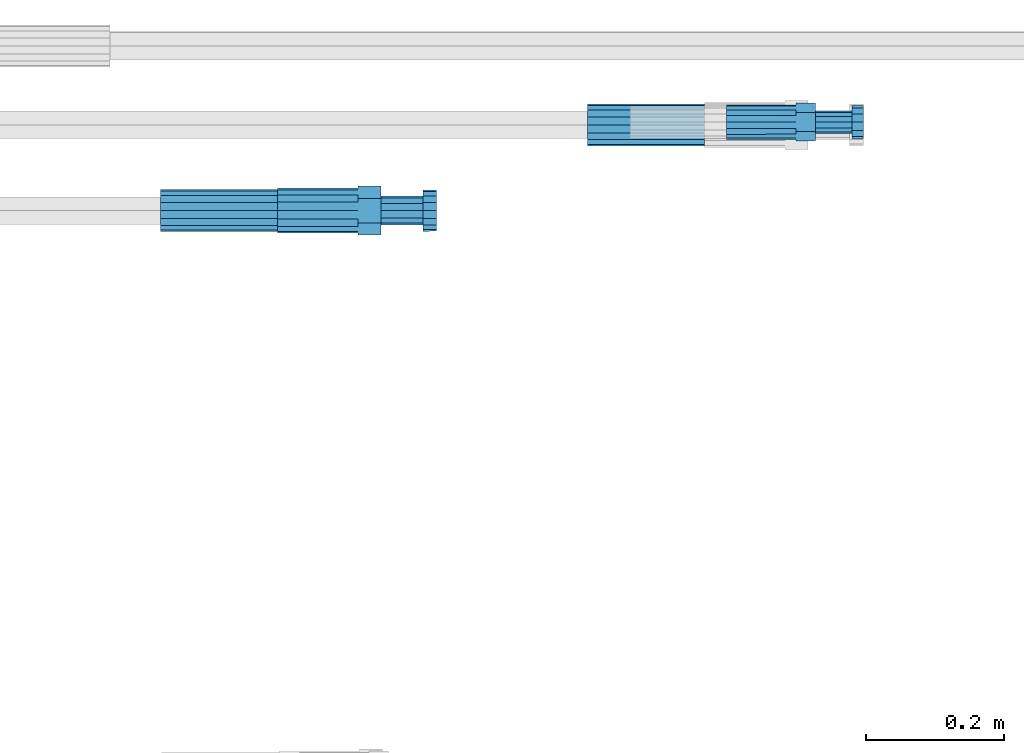
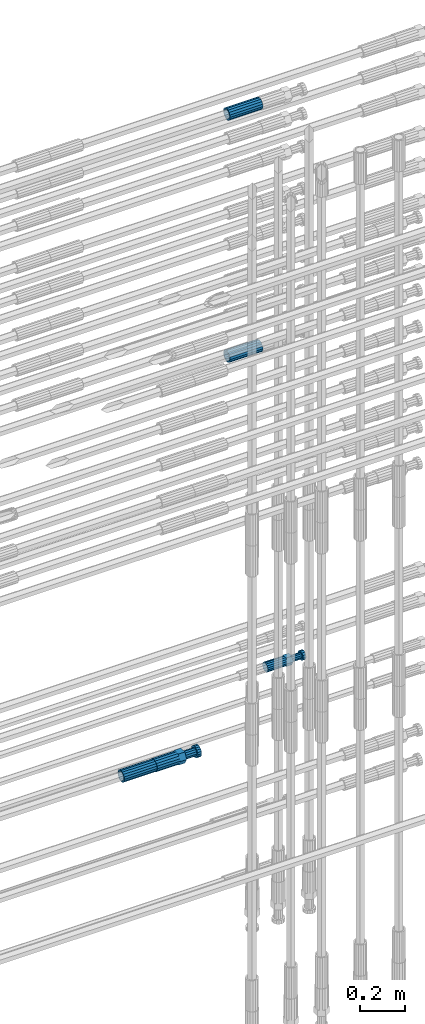
# One storey, part 109 of 119: 5 beams.
"""IFC2X3 building model written with IfcOpenShell, lengths in millimetres."""

from ifc_helpers import new_model, si_unit, frame, origin_with_axes, place, context, subcontext, project, spatial, faceted_brep, material, type_object, element, save


model = new_model("IFC2X3")

# Units and contexts
model_context = context("Model", 3, precision=1e-05, world=origin_with_axes())
body_context = subcontext(model_context, "Body", "Model", "MODEL_VIEW")
ifc_project = project(units=[si_unit("LENGTHUNIT", "METRE", prefix="MILLI"), si_unit("AREAUNIT", "SQUARE_METRE"), si_unit("VOLUMEUNIT", "CUBIC_METRE"), si_unit("MASSUNIT", "GRAM", prefix="KILO"), si_unit("TIMEUNIT", "SECOND"), si_unit("PLANEANGLEUNIT", "RADIAN"), si_unit("SOLIDANGLEUNIT", "STERADIAN"), si_unit("THERMODYNAMICTEMPERATUREUNIT", "DEGREE_CELSIUS"), si_unit("LUMINOUSINTENSITYUNIT", "LUMEN")], contexts=[model_context])

# Site, building, storey
site_placement = place(None, origin_with_axes())
site = spatial("IfcSite", under=ifc_project, at=site_placement, CompositionType="ELEMENT")
building_placement = place(site_placement, origin_with_axes())
building = spatial("IfcBuilding", under=site, at=building_placement, Name="Undefined", CompositionType="ELEMENT")
storey_placement = place(building_placement, origin_with_axes())
storey = spatial("IfcBuildingStorey", under=building, at=storey_placement, Name="Undefined", CompositionType="ELEMENT", Elevation=0.0)

# Beams
ifc_material = material(Name="STEEL/S275")
beam_type_1 = type_object("IfcBeamType", PredefinedType="NOTDEFINED")
beam_1_placement = place(storey_placement, frame((2038589.02023304, 6206285.48994599, 21026.9894117228), z_axis=(0.0, 0.0, 1.0), x_axis=(1.0, 0.0, 0.0)))
element("IfcBeam", 1, at=beam_1_placement, inside=storey, type_object=beam_type_1, material=ifc_material, Name="AG40N", context=body_context, shape_type="Brep", body=[
    faceted_brep([(1.62981450557709e-09, -23.4999999990687, 0.0), (7.45058059692383e-09, -21.7111690142192, 8.99306066057534), (170.000002125278, -21.711168999318, 8.99306066022245), (170.000002127141, -23.4999999844003, -3.66071617463604e-10), (4.65661287307739e-09, -16.6170093587134, 16.6170093578889), (170.000002122484, -16.6170093440451, 16.6170093575288), (1.86264514923096e-09, -8.99306066217832, 21.7111690140277), (170.000002118759, -8.99306064750999, 21.7111690136603), (2.3283064365387e-10, 9.31322574615479e-10, 23.5), (170.000002114102, 1.28056854009628e-08, 23.4999999996485), (-6.51925802230835e-09, 8.99306065868586, 21.7111690140241), (170.00000211224, 8.99306067335419, 21.7111690136639), (-7.45058059692383e-09, 16.6170093561523, 16.6170093578853), (170.000002109446, 16.6170093708206, 16.6170093575324), (-9.31322574615479e-09, 21.711169013055, 8.99306066057534), (170.000002108514, 21.7111690277234, 8.99306066022245), (-1.16415321826935e-09, 23.5000000009313, 0.0), (170.000002108514, 23.5000000144355, -3.66071617463604e-10), (-8.38190317153931e-09, 21.7111690151505, -8.99306066059444), (170.000002110377, 21.7111690300517, -8.9930606609546), (-5.58793544769287e-09, 16.6170093598776, -16.6170093579008), (170.000002113171, 16.6170093745459, -16.6170093582609), (-9.31322574615479e-10, 8.99306066334248, -21.7111690140396), (170.000002115965, 8.99306067801081, -21.7111690143961), (2.3283064365387e-10, 9.31322574615479e-10, -23.5), (170.00000211969, 1.7927959561348e-08, -23.5000000003843), (5.58793544769287e-09, -8.99306065752171, -21.7111690140396), (170.000002123415, -8.99306064285338, -21.7111690143961), (8.38190317153931e-09, -16.6170093549881, -16.6170093579008), (170.000002125278, -16.6170093403198, -16.6170093582646), (9.31322574615479e-09, -21.7111690121237, -8.99306066059444), (170.000002127141, -21.7111689972226, -8.9930606609546), (1.11758708953857e-08, -30.4999999990687, -9.54969436861575e-12), (1.30385160446167e-08, -28.1783257392235, -11.6718446871514), (170.000002129003, -28.1783257243223, -11.6718446875116), (170.000002129935, -30.4999999841675, -3.66071617463604e-10), (1.02445483207703e-08, -21.5667568228673, -21.5667568262129), (170.000002128072, -21.566756808199, -21.5667568265694), (7.45058059692383e-09, -11.6718446831219, -28.1783257416196), (170.000002125278, -11.6718446684536, -28.1783257419834), (3.72529029846191e-09, 3.95812094211578e-09, -30.5000000000277), (170.00000211969, 1.83936208486557e-08, -30.5000000003879), (-9.31322574615479e-10, 11.6718446905725, -28.1783257416232), (170.000002115965, 11.6718447052408, -28.1783257419797), (-6.51925802230835e-09, 21.5667568286881, -21.5667568262093), (170.000002110377, 21.5667568433564, -21.5667568265694), (-9.31322574615479e-09, 28.178325742716, -11.6718446871478), (170.000002108514, 28.1783257573843, -11.6718446875079), (-1.21071934700012e-08, 30.5, -5.91171556152403e-12), (170.000002106652, 30.5000000144355, -3.62433638656512e-10), (-1.21071934700012e-08, 28.1783257401548, 11.6718446871359), (170.00000210572, 28.1783257548232, 11.6718446867794), (-1.02445483207703e-08, 21.5667568240315, 21.5667568261974), (170.000002107583, 21.566756838467, 21.5667568258409), (-7.45058059692383e-09, 11.671844684286, 28.1783257416041), (170.000002110377, 11.6718446989544, 28.178325741244), (-2.79396772384644e-09, -2.56113708019257e-09, 30.5000000000159), (170.000002114102, 1.18743628263474e-08, 30.4999999996558), (1.86264514923096e-09, -11.6718446896411, 28.1783257416114), (170.000002118759, -11.67184467474, 28.178325741244), (7.45058059692383e-09, -21.5667568275239, 21.5667568261974), (170.000002123415, -21.5667568126228, 21.5667568258373), (1.02445483207703e-08, -28.1783257415518, 11.6718446871359), (170.000002127141, -28.1783257271163, 11.6718446867794)], [[[0, 1, 2, 3]], [[1, 4, 5, 2]], [[4, 6, 7, 5]], [[6, 8, 9, 7]], [[8, 10, 11, 9]], [[10, 12, 13, 11]], [[12, 14, 15, 13]], [[14, 16, 17, 15]], [[16, 18, 19, 17]], [[18, 20, 21, 19]], [[20, 22, 23, 21]], [[22, 24, 25, 23]], [[24, 26, 27, 25]], [[26, 28, 29, 27]], [[28, 30, 31, 29]], [[30, 0, 3, 31]], [[32, 33, 34, 35]], [[33, 36, 37, 34]], [[36, 38, 39, 37]], [[38, 40, 41, 39]], [[40, 42, 43, 41]], [[42, 44, 45, 43]], [[44, 46, 47, 45]], [[46, 48, 49, 47]], [[48, 50, 51, 49]], [[50, 52, 53, 51]], [[52, 54, 55, 53]], [[54, 56, 57, 55]], [[56, 58, 59, 57]], [[58, 60, 61, 59]], [[60, 62, 63, 61]], [[62, 32, 35, 63]], [[37, 39, 41, 43, 45, 47, 49, 51, 53, 55, 57, 59, 61, 63, 35, 34], [5, 7, 9, 11, 13, 15, 17, 19, 21, 23, 25, 27, 29, 31, 3, 2]], [[62, 60, 58, 56, 54, 52, 50, 48, 46, 44, 42, 40, 38, 36, 33, 32], [30, 28, 26, 24, 22, 20, 18, 16, 14, 12, 10, 8, 6, 4, 1, 0]]]),
])
beam_2_placement = place(storey_placement, frame((2038589.02023304, 6206285.48994599, 22354.9894117228), z_axis=(0.0, 0.0, 1.0), x_axis=(1.0, 0.0, 0.0)))
element("IfcBeam", 2, at=beam_2_placement, inside=storey, type_object=beam_type_1, material=ifc_material, Name="AG40N", context=body_context, shape_type="Brep", body=[
    faceted_brep([(1.62981450557709e-09, -23.4999999990687, 0.0), (7.45058059692383e-09, -21.7111690142192, 8.99306066057534), (170.000002125278, -21.711168999318, 8.99306066022245), (170.000002127141, -23.4999999844003, -3.66071617463604e-10), (4.65661287307739e-09, -16.6170093587134, 16.6170093578889), (170.000002122484, -16.6170093440451, 16.6170093575288), (1.86264514923096e-09, -8.99306066217832, 21.7111690140277), (170.000002118759, -8.99306064750999, 21.7111690136603), (2.3283064365387e-10, 9.31322574615479e-10, 23.5), (170.000002114102, 1.28056854009628e-08, 23.4999999996485), (-6.51925802230835e-09, 8.99306065868586, 21.7111690140241), (170.00000211224, 8.99306067335419, 21.7111690136639), (-7.45058059692383e-09, 16.6170093561523, 16.6170093578853), (170.000002109446, 16.6170093708206, 16.6170093575324), (-9.31322574615479e-09, 21.711169013055, 8.99306066057534), (170.000002108514, 21.7111690277234, 8.99306066022245), (-1.16415321826935e-09, 23.5000000009313, 0.0), (170.000002108514, 23.5000000144355, -3.66071617463604e-10), (-8.38190317153931e-09, 21.7111690151505, -8.99306066059444), (170.000002110377, 21.7111690300517, -8.9930606609546), (-5.58793544769287e-09, 16.6170093598776, -16.6170093579008), (170.000002113171, 16.6170093745459, -16.6170093582609), (-9.31322574615479e-10, 8.99306066334248, -21.7111690140396), (170.000002115965, 8.99306067801081, -21.7111690143961), (2.3283064365387e-10, 9.31322574615479e-10, -23.5), (170.00000211969, 1.7927959561348e-08, -23.5000000003843), (5.58793544769287e-09, -8.99306065752171, -21.7111690140396), (170.000002123415, -8.99306064285338, -21.7111690143961), (8.38190317153931e-09, -16.6170093549881, -16.6170093579008), (170.000002125278, -16.6170093403198, -16.6170093582646), (9.31322574615479e-09, -21.7111690121237, -8.99306066059444), (170.000002127141, -21.7111689972226, -8.9930606609546), (1.11758708953857e-08, -30.4999999990687, -9.54969436861575e-12), (1.30385160446167e-08, -28.1783257392235, -11.6718446871514), (170.000002129003, -28.1783257243223, -11.6718446875116), (170.000002129935, -30.4999999841675, -3.66071617463604e-10), (1.02445483207703e-08, -21.5667568228673, -21.5667568262129), (170.000002128072, -21.566756808199, -21.5667568265694), (7.45058059692383e-09, -11.6718446831219, -28.1783257416196), (170.000002125278, -11.6718446684536, -28.1783257419834), (3.72529029846191e-09, 3.95812094211578e-09, -30.5000000000277), (170.00000211969, 1.83936208486557e-08, -30.5000000003879), (-9.31322574615479e-10, 11.6718446905725, -28.1783257416232), (170.000002115965, 11.6718447052408, -28.1783257419797), (-6.51925802230835e-09, 21.5667568286881, -21.5667568262093), (170.000002110377, 21.5667568433564, -21.5667568265694), (-9.31322574615479e-09, 28.178325742716, -11.6718446871478), (170.000002108514, 28.1783257573843, -11.6718446875079), (-1.21071934700012e-08, 30.5, -5.91171556152403e-12), (170.000002106652, 30.5000000144355, -3.62433638656512e-10), (-1.21071934700012e-08, 28.1783257401548, 11.6718446871359), (170.00000210572, 28.1783257548232, 11.6718446867794), (-1.02445483207703e-08, 21.5667568240315, 21.5667568261974), (170.000002107583, 21.566756838467, 21.5667568258409), (-7.45058059692383e-09, 11.671844684286, 28.1783257416041), (170.000002110377, 11.6718446989544, 28.178325741244), (-2.79396772384644e-09, -2.56113708019257e-09, 30.5000000000159), (170.000002114102, 1.18743628263474e-08, 30.4999999996558), (1.86264514923096e-09, -11.6718446896411, 28.1783257416114), (170.000002118759, -11.67184467474, 28.178325741244), (7.45058059692383e-09, -21.5667568275239, 21.5667568261974), (170.000002123415, -21.5667568126228, 21.5667568258373), (1.02445483207703e-08, -28.1783257415518, 11.6718446871359), (170.000002127141, -28.1783257271163, 11.6718446867794)], [[[0, 1, 2, 3]], [[1, 4, 5, 2]], [[4, 6, 7, 5]], [[6, 8, 9, 7]], [[8, 10, 11, 9]], [[10, 12, 13, 11]], [[12, 14, 15, 13]], [[14, 16, 17, 15]], [[16, 18, 19, 17]], [[18, 20, 21, 19]], [[20, 22, 23, 21]], [[22, 24, 25, 23]], [[24, 26, 27, 25]], [[26, 28, 29, 27]], [[28, 30, 31, 29]], [[30, 0, 3, 31]], [[32, 33, 34, 35]], [[33, 36, 37, 34]], [[36, 38, 39, 37]], [[38, 40, 41, 39]], [[40, 42, 43, 41]], [[42, 44, 45, 43]], [[44, 46, 47, 45]], [[46, 48, 49, 47]], [[48, 50, 51, 49]], [[50, 52, 53, 51]], [[52, 54, 55, 53]], [[54, 56, 57, 55]], [[56, 58, 59, 57]], [[58, 60, 61, 59]], [[60, 62, 63, 61]], [[62, 32, 35, 63]], [[37, 39, 41, 43, 45, 47, 49, 51, 53, 55, 57, 59, 61, 63, 35, 34], [5, 7, 9, 11, 13, 15, 17, 19, 21, 23, 25, 27, 29, 31, 3, 2]], [[62, 60, 58, 56, 54, 52, 50, 48, 46, 44, 42, 40, 38, 36, 33, 32], [30, 28, 26, 24, 22, 20, 18, 16, 14, 12, 10, 8, 6, 4, 1, 0]]]),
])
beam_3_placement = place(storey_placement, frame((2037969.03023304, 6206160.98994599, 19018.4894151562), z_axis=(0.0, 0.0, 1.0), x_axis=(1.0, 0.0, 0.0)))
element("IfcBeam", 3, at=beam_3_placement, inside=storey, type_object=beam_type_1, material=ifc_material, Name="AG40N", context=body_context, shape_type="Brep", body=[
    faceted_brep([(1.62981450557709e-09, -23.4999999990687, 0.0), (7.45058059692383e-09, -21.7111690142192, 8.99306066057534), (170.000002125278, -21.711168999318, 8.99306066022245), (170.000002127141, -23.4999999844003, -3.66071617463604e-10), (4.65661287307739e-09, -16.6170093587134, 16.6170093578889), (170.000002122484, -16.6170093440451, 16.6170093575288), (1.86264514923096e-09, -8.99306066217832, 21.7111690140277), (170.000002118759, -8.99306064750999, 21.7111690136603), (2.3283064365387e-10, 9.31322574615479e-10, 23.5), (170.000002114102, 1.28056854009628e-08, 23.4999999996485), (-6.51925802230835e-09, 8.99306065868586, 21.7111690140241), (170.00000211224, 8.99306067335419, 21.7111690136639), (-7.45058059692383e-09, 16.6170093561523, 16.6170093578853), (170.000002109446, 16.6170093708206, 16.6170093575324), (-9.31322574615479e-09, 21.711169013055, 8.99306066057534), (170.000002108514, 21.7111690277234, 8.99306066022245), (-1.16415321826935e-09, 23.5000000009313, 0.0), (170.000002108514, 23.5000000144355, -3.66071617463604e-10), (-8.38190317153931e-09, 21.7111690151505, -8.99306066059444), (170.000002110377, 21.7111690300517, -8.9930606609546), (-5.58793544769287e-09, 16.6170093598776, -16.6170093579008), (170.000002113171, 16.6170093745459, -16.6170093582609), (-9.31322574615479e-10, 8.99306066334248, -21.7111690140396), (170.000002115965, 8.99306067801081, -21.7111690143961), (2.3283064365387e-10, 9.31322574615479e-10, -23.5), (170.00000211969, 1.7927959561348e-08, -23.5000000003843), (5.58793544769287e-09, -8.99306065752171, -21.7111690140396), (170.000002123415, -8.99306064285338, -21.7111690143961), (8.38190317153931e-09, -16.6170093549881, -16.6170093579008), (170.000002125278, -16.6170093403198, -16.6170093582646), (9.31322574615479e-09, -21.7111690121237, -8.99306066059444), (170.000002127141, -21.7111689972226, -8.9930606609546), (1.11758708953857e-08, -30.4999999990687, -9.54969436861575e-12), (1.30385160446167e-08, -28.1783257392235, -11.6718446871514), (170.000002129003, -28.1783257243223, -11.6718446875116), (170.000002129935, -30.4999999841675, -3.66071617463604e-10), (1.02445483207703e-08, -21.5667568228673, -21.5667568262129), (170.000002128072, -21.566756808199, -21.5667568265694), (7.45058059692383e-09, -11.6718446831219, -28.1783257416196), (170.000002125278, -11.6718446684536, -28.1783257419834), (3.72529029846191e-09, 3.95812094211578e-09, -30.5000000000277), (170.00000211969, 1.83936208486557e-08, -30.5000000003879), (-9.31322574615479e-10, 11.6718446905725, -28.1783257416232), (170.000002115965, 11.6718447052408, -28.1783257419797), (-6.51925802230835e-09, 21.5667568286881, -21.5667568262093), (170.000002110377, 21.5667568433564, -21.5667568265694), (-9.31322574615479e-09, 28.178325742716, -11.6718446871478), (170.000002108514, 28.1783257573843, -11.6718446875079), (-1.21071934700012e-08, 30.5, -5.91171556152403e-12), (170.000002106652, 30.5000000144355, -3.62433638656512e-10), (-1.21071934700012e-08, 28.1783257401548, 11.6718446871359), (170.00000210572, 28.1783257548232, 11.6718446867794), (-1.02445483207703e-08, 21.5667568240315, 21.5667568261974), (170.000002107583, 21.566756838467, 21.5667568258409), (-7.45058059692383e-09, 11.671844684286, 28.1783257416041), (170.000002110377, 11.6718446989544, 28.178325741244), (-2.79396772384644e-09, -2.56113708019257e-09, 30.5000000000159), (170.000002114102, 1.18743628263474e-08, 30.4999999996558), (1.86264514923096e-09, -11.6718446896411, 28.1783257416114), (170.000002118759, -11.67184467474, 28.178325741244), (7.45058059692383e-09, -21.5667568275239, 21.5667568261974), (170.000002123415, -21.5667568126228, 21.5667568258373), (1.02445483207703e-08, -28.1783257415518, 11.6718446871359), (170.000002127141, -28.1783257271163, 11.6718446867794)], [[[0, 1, 2, 3]], [[1, 4, 5, 2]], [[4, 6, 7, 5]], [[6, 8, 9, 7]], [[8, 10, 11, 9]], [[10, 12, 13, 11]], [[12, 14, 15, 13]], [[14, 16, 17, 15]], [[16, 18, 19, 17]], [[18, 20, 21, 19]], [[20, 22, 23, 21]], [[22, 24, 25, 23]], [[24, 26, 27, 25]], [[26, 28, 29, 27]], [[28, 30, 31, 29]], [[30, 0, 3, 31]], [[32, 33, 34, 35]], [[33, 36, 37, 34]], [[36, 38, 39, 37]], [[38, 40, 41, 39]], [[40, 42, 43, 41]], [[42, 44, 45, 43]], [[44, 46, 47, 45]], [[46, 48, 49, 47]], [[48, 50, 51, 49]], [[50, 52, 53, 51]], [[52, 54, 55, 53]], [[54, 56, 57, 55]], [[56, 58, 59, 57]], [[58, 60, 61, 59]], [[60, 62, 63, 61]], [[62, 32, 35, 63]], [[37, 39, 41, 43, 45, 47, 49, 51, 53, 55, 57, 59, 61, 63, 35, 34], [5, 7, 9, 11, 13, 15, 17, 19, 21, 23, 25, 27, 29, 31, 3, 2]], [[62, 60, 58, 56, 54, 52, 50, 48, 46, 44, 42, 40, 38, 36, 33, 32], [30, 28, 26, 24, 22, 20, 18, 16, 14, 12, 10, 8, 6, 4, 1, 0]]]),
])
beam_type_2 = type_object("IfcBeamType", Name="ROD65", PredefinedType="NOTDEFINED")
beam_4_placement = place(storey_placement, frame((2038139.03023304, 6206160.98994599, 19018.4894184159), z_axis=(0.0, 0.0, 1.0), x_axis=(1.0, 0.0, 0.0)))
element("IfcBeam", 4, at=beam_4_placement, inside=storey, type_object=beam_type_2, material=ifc_material, Name="AGB40", ObjectType="ROD65", context=body_context, shape_type="Brep", body=[
    faceted_brep([(116.999999999069, 17.8249999252148, 30.8738056446964), (116.999999998137, 22.0056957420893, 23.632628078838), (116.999999999069, 12.4372115600854, 30.0260848066173), (116.999999999069, 8.17543111252598, 30.8738056446964), (117.000000000931, -17.8250000746921, 30.8738056446964), (150.200000001118, -17.8250000723638, 30.8738056446964), (150.199999999255, 17.8249999275431, 30.8738056446964), (117.000000000931, -8.17543109622784, 30.8738056446964), (117.000000001863, -22.0056959956419, 23.6326278985034), (117.000000000931, -12.4372115437873, 30.0260848066173), (117.000000001863, -35.6500000746455, -2.18278728425503e-10), (150.200000002049, -35.6500000723172, -2.18278728425503e-10), (117.000000001863, -30.8443149488885, 8.32369080289209), (117.000000001863, -30.8443149488885, -8.32369080355784), (117.000000002794, -32.4999999918509, 0.0), (117.000000000931, -17.8250000746921, -30.873805645133), (150.200000001118, -17.8250000723638, -30.873805645133), (117.000000001863, -22.0056959961075, -23.6326278982269), (117.000000000931, -8.17543109389953, -30.873805645133), (117.000000000931, -12.4372115437873, -30.0260848066173), (116.999999999069, 17.8249999252148, -30.873805645133), (150.199999999255, 17.8249999275431, -30.873805645133), (116.999999999069, 8.17543111019768, -30.873805645133), (116.999999999069, 12.4372115600854, -30.0260848066173), (116.999999998137, 22.005695742555, -23.6326280785652), (116.999999998137, 35.6499999251682, -2.18278728425503e-10), (150.199999998324, 35.6499999277294, -2.18278728425503e-10), (116.999999998137, 30.8443150522653, -8.32369036550881), (116.999999997206, 32.5000000081491, 0.0), (116.999999998137, 30.8443150522653, 8.32369036483942), (1.86264514923096e-09, -22.9809703885112, 22.9809703885621), (1.86264514923096e-09, -30.0260848065373, 12.4372115518672), (117.000000001863, -30.0260847983882, 12.4372115518672), (117.000000001863, -22.9809703803621, 22.9809703885621), (-1.86264514923096e-09, 22.9809703885112, -22.9809703885621), (-1.86264514923096e-09, 30.0260848065373, -12.4372115518672), (116.999999998137, 30.0260848146863, -12.4372115518672), (116.999999998137, 22.9809703966603, -22.9809703885621), (1.86264514923096e-09, -30.0260848065373, -12.4372115518672), (1.86264514923096e-09, -22.9809703885112, -22.9809703885621), (117.000000001863, -22.9809703803621, -22.9809703885621), (117.000000001863, -30.0260847983882, -12.4372115518672), (9.31322574615479e-10, -12.4372115519363, 30.0260848066173), (0.0, 0.0, 32.5), (-9.31322574615479e-10, 12.4372115519363, 30.0260848066173), (-1.86264514923096e-09, 22.9809703885112, 22.9809703885621), (-1.86264514923096e-09, 30.0260848065373, 12.4372115518672), (-2.79396772384644e-09, 32.5, 0.0), (-9.31322574615479e-10, 12.4372115519363, -30.0260848066173), (0.0, 0.0, -32.5), (9.31322574615479e-10, -12.4372115519363, -30.0260848066173), (2.79396772384644e-09, -32.5, 0.0), (116.999999998137, 22.9809703966603, 22.9809703885621), (116.999999998137, 30.0260848146863, 12.4372115518672), (117.0, 8.14907252788544e-09, -32.5), (117.0, 8.14907252788544e-09, 32.5), (150.200000000186, -10.5000000959262, 18.1865334791873), (150.199999999255, -9.59262251853943e-08, 20.9999999997126), (150.199999998324, 10.4999999040738, 18.1865334791873), (150.199999997392, 18.1865333835594, 10.4999999997126), (150.199999997392, 20.9999999040738, -2.87400325760245e-10), (150.199999997392, 18.1865333835594, -10.5000000002874), (150.199999998324, 10.4999999040738, -18.1865334797621), (150.199999999255, -9.59262251853943e-08, -21.0000000002874), (150.200000000186, -10.5000000959262, -18.1865334797621), (150.200000000186, -18.1865335754119, -10.5000000002874), (150.200000001118, -21.0000000959262, -2.87400325760245e-10), (150.200000000186, -18.1865335754119, 10.4999999997126), (210.979999999516, 10.4999999082647, 18.1865334791873), (210.979999999516, -9.17352735996246e-08, 20.9999999997126), (210.979999997653, 18.1865333877504, 10.4999999997126), (210.979999997653, 20.9999999082647, -2.87400325760245e-10), (210.979999997653, 18.1865333877504, -10.5000000002874), (210.979999999516, 10.4999999082647, -18.1865334797621), (210.979999999516, -9.17352735996246e-08, -21.0000000002874), (210.979999999516, -10.5000000917353, -18.1865334797621), (210.980000000447, -18.1865335712209, -10.5000000002874), (210.980000001378, -21.0000000917353, -2.87400325760245e-10), (210.980000000447, -18.1865335712209, 10.4999999997126), (210.979999999516, -10.5000000917353, 18.1865334791873), (211.001368402503, -27.7269939335529, -11.4911163272045), (211.003082515672, -21.2238095656503, -21.2238154190527), (231.002518340945, -21.2131946226582, -21.2132004554769), (231.000804228708, -27.7163789905608, -11.4805013636287), (211.001368415542, -11.4911086384673, -27.7269970399575), (231.000804241747, -11.4804936954752, -27.7163820763781), (210.996487061493, -0.0106066407170147, -30.0106107396168), (230.995922887698, 8.30227509140968e-06, -29.999995776041), (210.98918159306, 11.4698940692469, -27.7269970332745), (230.988617419265, 11.4805090120062, -27.7163820696951), (210.980564201251, 21.2025913291145, -21.2238154067054), (230.980000027455, 21.2132062721066, -21.2132004431296), (210.971946807578, 27.7057702087332, -11.4911163110701), (230.971382633783, 27.7163851517253, -11.4805013474943), (210.964641331695, 29.9893806746695, -0.0106149565435771), (230.9640771579, 29.9999956176616, 7.03221303410828e-09), (210.959759964608, 27.7057637346443, 11.4698863966551), (230.959195790812, 27.7163786776364, 11.4805013602345), (210.958045851439, 21.2025793667417, 21.2025854885032), (230.957481677644, 21.2131943097338, 21.2132004520827), (210.959759951569, 11.4698784395587, 27.705767109408), (230.959195776843, 11.4804933823179, 27.7163820729838), (210.964641305618, -0.0106235581915826, 29.9893808090674), (230.964077131823, -8.61519947648048e-06, 29.9999957726432), (210.971946774051, -11.4911242681555, 27.7057671027251), (230.971382599324, -11.4805093251634, 27.7163820663009), (210.98056416586, -21.2238215280231, 21.2025854761559), (230.979999991134, -21.2132065852638, 21.2132004397354), (210.989181559533, -27.7270004076418, 11.4698863805206), (230.988617384806, -27.7163854646496, 11.4805013441), (210.996487035416, -30.0106108735781, -0.0106149740058754), (230.995922861621, -29.999995930586, -1.04300852399319e-08)], [[[0, 1, 2, 3]], [[4, 5, 6, 0, 3, 7]], [[8, 4, 7, 9]], [[10, 11, 5, 4, 8, 12]], [[13, 10, 12, 14]], [[15, 16, 11, 10, 13, 17]], [[18, 15, 17, 19]], [[20, 21, 16, 15, 18, 22]], [[20, 22, 23, 24]], [[25, 26, 21, 20, 24, 27]], [[25, 27, 28, 29]], [[30, 31, 32, 33]], [[34, 35, 36, 37]], [[38, 39, 40, 41]], [[31, 30, 42, 43, 44, 45, 46, 47, 35, 34, 48, 49, 50, 39, 38, 51]], [[46, 45, 52, 53]], [[28, 47, 46, 53, 29]], [[27, 36, 35, 47, 28]], [[24, 37, 36, 27]], [[23, 48, 34, 37, 24]], [[22, 54, 49, 48, 23]], [[18, 54, 22]], [[19, 50, 49, 54, 18]], [[17, 40, 39, 50, 19]], [[13, 41, 40, 17]], [[14, 51, 38, 41, 13]], [[12, 32, 31, 51, 14]], [[8, 33, 32, 12]], [[9, 42, 30, 33, 8]], [[7, 55, 43, 42, 9]], [[3, 55, 7]], [[2, 44, 43, 55, 3]], [[1, 52, 45, 44, 2]], [[29, 53, 52, 1]], [[0, 6, 26, 25, 29, 1]], [[5, 11, 16, 21, 26, 6], [56, 57, 58, 59, 60, 61, 62, 63, 64, 65, 66, 67]], [[68, 58, 57, 69]], [[70, 59, 58, 68]], [[71, 60, 59, 70]], [[72, 61, 60, 71]], [[73, 62, 61, 72]], [[74, 63, 62, 73]], [[75, 64, 63, 74]], [[76, 65, 64, 75]], [[77, 66, 65, 76]], [[78, 67, 66, 77]], [[79, 56, 67, 78]], [[69, 57, 56, 79]], [[80, 81, 82, 83]], [[81, 84, 85, 82]], [[84, 86, 87, 85]], [[86, 88, 89, 87]], [[88, 90, 91, 89]], [[90, 92, 93, 91]], [[92, 94, 95, 93]], [[94, 96, 97, 95]], [[96, 98, 99, 97]], [[98, 100, 101, 99]], [[100, 102, 103, 101]], [[102, 104, 105, 103]], [[104, 106, 107, 105]], [[106, 108, 109, 107]], [[108, 110, 111, 109]], [[82, 85, 87, 89, 91, 93, 95, 97, 99, 101, 103, 105, 107, 109, 111, 83]], [[110, 80, 83, 111]], [[108, 106, 104, 102, 100, 98, 96, 94, 92, 90, 88, 86, 84, 81, 80, 110], [78, 77, 76, 75, 74, 73, 72, 71, 70, 68, 69, 79]]]),
])
beam_type_3 = type_object("IfcBeamType", Name="ROD50", PredefinedType="NOTDEFINED")
beam_5_placement = place(storey_placement, frame((2038791.00023304, 6206289.47994599, 19249.489419125), z_axis=(0.0, 0.0, 1.0), x_axis=(1.0, 0.0, 0.0)))
element("IfcBeam", 5, at=beam_5_placement, inside=storey, type_object=beam_type_3, material=ifc_material, Name="AGB32", ObjectType="ROD50", context=body_context, shape_type="Brep", body=[
    faceted_brep([(100.999999995111, 13.8425000002608, 23.9759132212093), (100.999999996508, 17.5285119004548, 17.5915533324223), (100.999999997672, 9.56708580907434, 23.0969883129546), (100.999999995111, 5.14843190740794, 23.9759132212093), (100.999999995111, -13.8425000002608, 23.9759132212093), (129.099999995669, -13.8425000002608, 23.9759132182917), (129.099999995669, 13.8425000002608, 23.9759132182917), (100.999999995111, -5.14843190740794, 23.9759132212093), (100.999999996508, -17.5285119004548, 17.5915533324223), (100.999999997672, -9.56708580907434, 23.0969883129546), (101.000000000233, -27.6849999995902, -8.25639290269464e-08), (129.100000000792, -27.6849999995902, -8.5481588030234e-08), (100.999999998836, -23.5887256683782, 7.09495518143376), (101.00000000163, -23.5887256180868, -7.09495543353478), (101.000000000233, -25.0, 1.70985003933311e-10), (101.000000005355, -13.8425000002608, -23.9759133863372), (129.100000005914, -13.8425000002608, -23.9759133892549), (101.000000003958, -17.5285119721666, -17.5915533734478), (101.000000005355, -5.14843107573688, -23.9759133863372), (101.000000002561, -9.56708580907434, -23.0969883126127), (101.000000005355, 13.8425000002608, -23.9759133863372), (129.100000005914, 13.8425000002608, -23.9759133892549), (101.000000005355, 5.14843107573688, -23.9759133863372), (101.000000002561, 9.56708580907434, -23.0969883126127), (101.000000003958, 17.5285119721666, -17.5915533734478), (101.000000000233, 27.6849999995902, -8.25639290269464e-08), (129.100000000792, 27.6849999995902, -8.5481588030234e-08), (101.00000000163, 23.5887256180868, -7.09495543353478), (101.000000000233, 25.0, 1.70985003933311e-10), (100.999999998836, 23.5887256683782, 7.09495518143376), (-6.98491930961609e-10, -23.0969883129001, 9.56708580912891), (-1.62981450557709e-09, -17.6776695298031, 17.6776695296649), (-2.3283064365387e-09, -9.56708580907434, 23.0969883127837), (-2.56113708019257e-09, 0.0, 25.0), (-2.3283064365387e-09, 9.56708580907434, 23.0969883127837), (-1.62981450557709e-09, 17.6776695298031, 17.6776695296649), (-6.98491930961609e-10, 23.0969883129001, 9.56708580912891), (2.3283064365387e-10, 25.0, 0.0), (1.16415321826935e-09, 23.0969883129001, -9.56708580912891), (2.09547579288483e-09, 17.6776695298031, -17.6776695296649), (2.56113708019257e-09, 9.56708580907434, -23.0969883127837), (2.79396772384644e-09, 0.0, -25.0), (2.56113708019257e-09, -9.56708580907434, -23.0969883127837), (2.09547579288483e-09, -17.6776695298031, -17.6776695296649), (1.16415321826935e-09, -23.0969883129001, -9.56708580912891), (2.3283064365387e-10, -25.0, 0.0), (100.999999999302, 23.0969883129001, 9.5670858092999), (101.000000001164, 23.0969883129001, -9.56708580895793), (101.000000002794, 0.0, -24.999999999829), (101.000000001164, -23.0969883129001, -9.56708580895793), (100.999999999302, -23.0969883129001, 9.5670858092999), (100.999999997439, 0.0, 25.000000000171), (129.49999999837, -14.2894191620871, 8.24999989414209), (129.499999996973, -8.25, 14.2894190565821), (129.49999999674, 0.0, 16.4999998941421), (129.499999996973, 8.25, 14.2894190565821), (129.49999999837, 14.2894191620871, 8.24999989414209), (129.500000000233, 16.5, -1.05857907328755e-07), (129.500000002095, 14.2894191620871, -8.25000010585791), (129.50000000326, 8.25, -14.2894192683016), (129.500000003492, 0.0, -16.5000001058615), (129.50000000326, -8.25, -14.2894192683016), (129.500000002095, -14.2894191620871, -8.25000010586155), (129.500000000233, -16.5, -1.05857907328755e-07), (182.499999996973, 8.25, 14.2894190510815), (182.49999999674, 0.0, 16.4999998886415), (182.49999999837, 14.2894191620871, 8.24999988864147), (182.500000000233, 16.5, -1.11358531285077e-07), (182.500000002095, 14.2894191620871, -8.25000011135853), (182.50000000326, 8.25, -14.2894192738022), (182.500000003492, 0.0, -16.5000001113622), (182.50000000326, -8.25, -14.2894192738022), (182.500000002095, -14.2894191620871, -8.25000011136217), (182.500000000233, -16.5, -1.11358531285077e-07), (182.49999999837, -14.2894191620871, 8.24999988864147), (182.499999996973, -8.25, 14.2894190510815), (182.500000002561, -20.7846096912399, -12.0000001491826), (182.500000004657, -12.0, -20.7846098400078), (199.000000004657, -12.0, -20.7846098417212), (199.000000002561, -20.7846096912399, -12.0000001508961), (182.500000005355, 0.0, -24.0000001491826), (199.000000005355, 0.0, -24.0000001508961), (182.500000004657, 12.0, -20.7846098400078), (199.000000004657, 12.0, -20.7846098417212), (182.500000002561, 20.7846096912399, -12.000000149179), (199.000000002561, 20.7846096912399, -12.0000001508924), (182.500000000233, 24.0, -1.49178958963603e-07), (199.000000000233, 24.0, -1.50892446981743e-07), (182.499999997672, 20.7846096912399, 11.999999850821), (198.999999997672, 20.7846096912399, 11.9999998491076), (182.499999995809, 12.0, 20.7846095416462), (198.999999995809, 12.0, 20.7846095399327), (182.499999995111, 0.0, 23.999999850821), (198.999999995111, 0.0, 23.9999998491076), (182.499999995809, -12.0, 20.7846095416462), (198.999999995809, -12.0, 20.7846095399327), (182.499999997672, -20.7846096912399, 11.999999850821), (198.999999997672, -20.7846096912399, 11.9999998491039), (182.500000000233, -24.0, -1.49178958963603e-07), (199.000000000233, -24.0, -1.50892446981743e-07)], [[[0, 1, 2, 3]], [[4, 5, 6, 0, 3, 7]], [[8, 4, 7, 9]], [[10, 11, 5, 4, 8, 12]], [[13, 10, 12, 14]], [[15, 16, 11, 10, 13, 17]], [[18, 15, 17, 19]], [[20, 21, 16, 15, 18, 22]], [[20, 22, 23, 24]], [[25, 26, 21, 20, 24, 27]], [[25, 27, 28, 29]], [[30, 31, 32, 33, 34, 35, 36, 37, 38, 39, 40, 41, 42, 43, 44, 45]], [[28, 37, 36, 46, 29]], [[27, 47, 38, 37, 28]], [[24, 47, 27]], [[39, 38, 47, 24]], [[23, 40, 39, 24]], [[22, 48, 41, 40, 23]], [[18, 48, 22]], [[19, 42, 41, 48, 18]], [[17, 43, 42, 19]], [[44, 43, 17, 49]], [[13, 49, 17]], [[14, 45, 44, 49, 13]], [[12, 50, 30, 45, 14]], [[8, 50, 12]], [[31, 30, 50, 8]], [[9, 32, 31, 8]], [[7, 51, 33, 32, 9]], [[3, 51, 7]], [[2, 34, 33, 51, 3]], [[1, 35, 34, 2]], [[36, 35, 1, 46]], [[29, 46, 1]], [[0, 6, 26, 25, 29, 1]], [[5, 11, 16, 21, 26, 6]], [[52, 53, 54, 55, 56, 57, 58, 59, 60, 61, 62, 63]], [[64, 55, 54, 65]], [[66, 56, 55, 64]], [[67, 57, 56, 66]], [[68, 58, 57, 67]], [[69, 59, 58, 68]], [[70, 60, 59, 69]], [[71, 61, 60, 70]], [[72, 62, 61, 71]], [[73, 63, 62, 72]], [[74, 52, 63, 73]], [[75, 53, 52, 74]], [[65, 54, 53, 75]], [[76, 77, 78, 79]], [[77, 80, 81, 78]], [[80, 82, 83, 81]], [[82, 84, 85, 83]], [[84, 86, 87, 85]], [[86, 88, 89, 87]], [[88, 90, 91, 89]], [[90, 92, 93, 91]], [[92, 94, 95, 93]], [[94, 96, 97, 95]], [[96, 98, 99, 97]], [[78, 81, 83, 85, 87, 89, 91, 93, 95, 97, 99, 79]], [[98, 76, 79, 99]], [[96, 94, 92, 90, 88, 86, 84, 82, 80, 77, 76, 98], [74, 73, 72, 71, 70, 69, 68, 67, 66, 64, 65, 75]]]),
])

save(model, "model.ifc")
